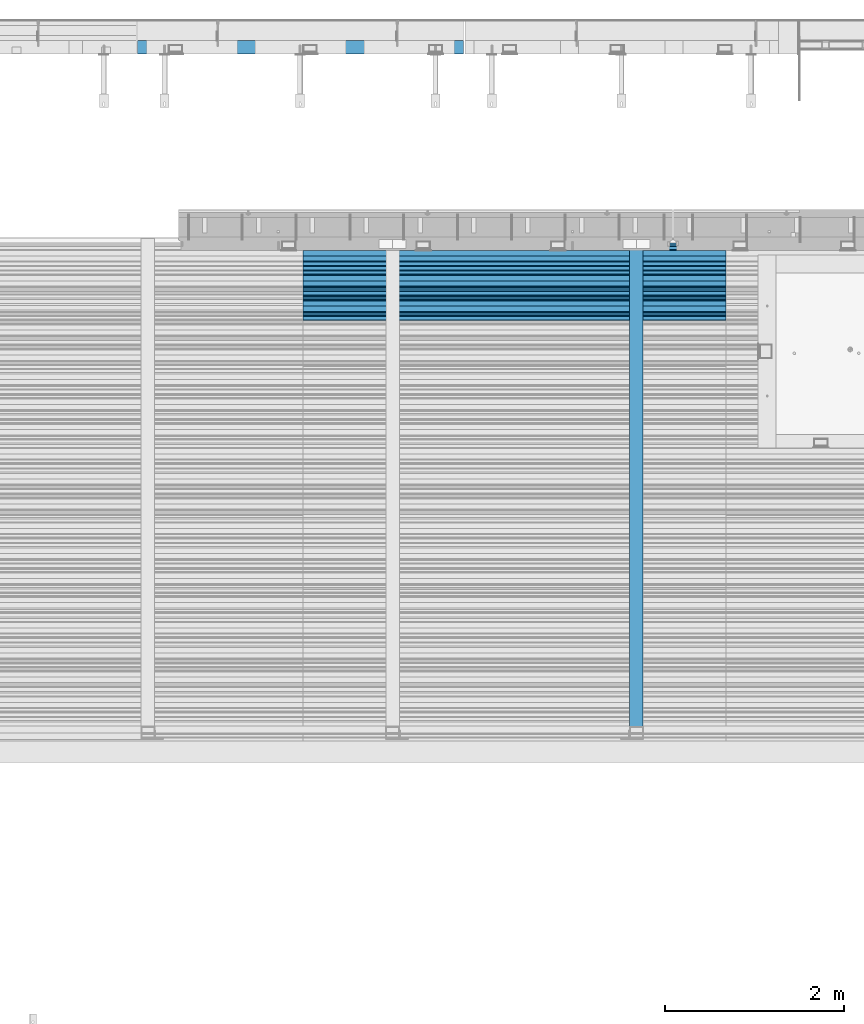
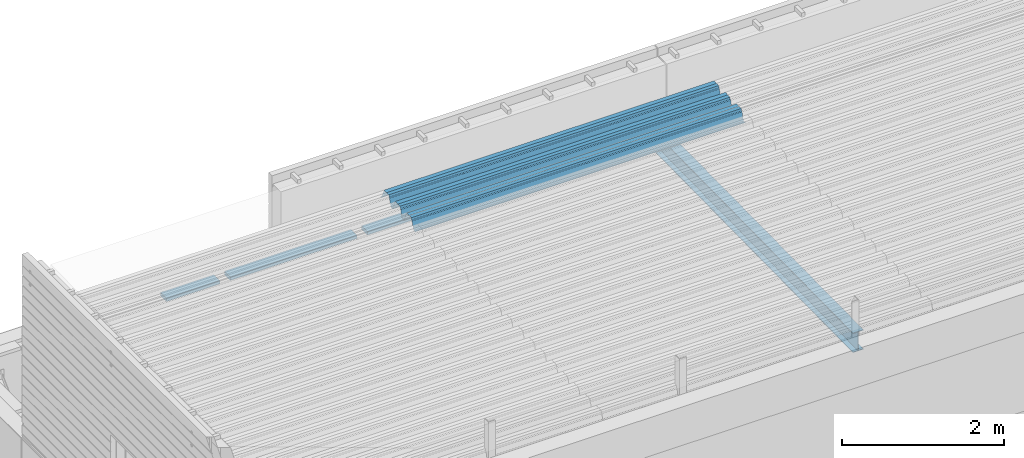
# One storey, part 36 of 153: 3 beams, 3 elements without a shape of their own.
"""IFC2X3 building model written with IfcOpenShell, lengths in millimetres."""

from ifc_helpers import new_model, si_unit, frame, origin_with_axes, place, context, subcontext, project, spatial, faceted_brep, material, type_object, element, aggregate, save


model = new_model("IFC2X3")

# Units and contexts
model_context = context("Model", 3, precision=1e-05, world=origin_with_axes())
body_context = subcontext(model_context, "Body", "Model", "MODEL_VIEW")
ifc_project = project(units=[si_unit("LENGTHUNIT", "METRE", prefix="MILLI"), si_unit("AREAUNIT", "SQUARE_METRE"), si_unit("VOLUMEUNIT", "CUBIC_METRE"), si_unit("MASSUNIT", "GRAM", prefix="KILO"), si_unit("TIMEUNIT", "SECOND"), si_unit("PLANEANGLEUNIT", "RADIAN"), si_unit("SOLIDANGLEUNIT", "STERADIAN"), si_unit("THERMODYNAMICTEMPERATUREUNIT", "DEGREE_CELSIUS"), si_unit("LUMINOUSINTENSITYUNIT", "LUMEN")], contexts=[model_context])

# Site, building, storey
site_placement = place(None, origin_with_axes())
site = spatial("IfcSite", under=ifc_project, at=site_placement, CompositionType="ELEMENT")
building_placement = place(site_placement, origin_with_axes())
building = spatial("IfcBuilding", under=site, at=building_placement, CompositionType="ELEMENT")
storey_placement = place(building_placement, origin_with_axes())
storey = spatial("IfcBuildingStorey", under=building, at=storey_placement, Name="8", CompositionType="ELEMENT", Elevation=0.0)

# Assembly, beam
assembly_1_placement = place(storey_placement, origin_with_axes())
assembly_1 = element("IfcElementAssembly", 1, at=assembly_1_placement, inside=storey, AssemblyPlace="NOTDEFINED", PredefinedType="REINFORCEMENT_UNIT")
ifc_material_1 = material(Name="TIMBER")
beam_type_1 = type_object("IfcBeamType", PredefinedType="NOTDEFINED")
beam_1_placement = place(assembly_1_placement, frame((10692.5, 22695.0, 103545.0), z_axis=(0.0, 0.0, 1.0), x_axis=(1.0, 0.0, 0.0)))
beam_1 = element("IfcBeam", 2, at=beam_1_placement, type_object=beam_type_1, material=ifc_material_1, context=body_context, shape_type="Brep", body=[
    faceted_brep([(0.0, -75.0, -25.0), (1.81898940354586e-12, -75.0000000000009, 25.0), (1.81898940354586e-12, 75.0, 25.0), (0.0, 75.0, -25.0), (761.499676343077, -75.0, -25.0), (761.499676343077, -75.0, 25.0), (761.499640793076, 74.9998429442203, 25.0), (761.499640793076, 75.0, -25.0), (2871.49964079283, 74.9998784942218, 25.0), (2871.49964079283, 75.0, -25.0), (2871.49967634307, -75.0, -25.0), (2871.49967634307, -75.0, 25.0), (3632.5, -75.0, 25.0), (3632.5, -75.0, -25.0), (3632.5, 75.0, -25.0), (3632.5, 75.0, 25.0), (2721.49964079308, 74.9998429442203, 25.0), (2721.49967634308, -75.0, 25.0), (2721.49967634308, -75.0, -25.0), (2721.49964079308, 75.0, -25.0), (911.499640792827, 74.9998784942218, 25.0), (911.499640792827, 75.0, -25.0), (911.499676343072, -75.0, -25.0), (911.499676343072, -75.0, 25.0)], [[[0, 1, 2, 3]], [[1, 0, 4, 5]], [[2, 1, 5, 6]], [[3, 2, 6, 7]], [[0, 3, 7, 4]], [[6, 5, 4, 7]], [[8, 9, 10, 11]], [[12, 13, 14, 15]], [[12, 15, 8, 11]], [[13, 12, 11, 10]], [[14, 13, 10, 9]], [[15, 14, 9, 8]], [[16, 17, 18, 19]], [[20, 21, 22, 23]], [[21, 20, 16, 19]], [[22, 21, 19, 18]], [[23, 22, 18, 17]], [[20, 23, 17, 16]]]),
])
aggregate(assembly_1, [beam_1])

assembly_2_placement = place(storey_placement, origin_with_axes())
assembly_2 = element("IfcElementAssembly", 3, at=assembly_2_placement, inside=storey, Name="Steel Assembly", AssemblyPlace="NOTDEFINED", PredefinedType="RIGID_FRAME")
ifc_material_2 = material(Name="STEEL/S355J2")
beam_type_2 = type_object("IfcBeamType", Name="IPE300", PredefinedType="NOTDEFINED")
beam_2_placement = place(assembly_2_placement, frame((16252.0, 15128.0908589909, 105518.668698015), z_axis=(0.0, -0.0124990270013869, 0.999921884110963), x_axis=(0.0, 0.999921884110963, 0.0124990270013883)))
beam_2 = element("IfcBeam", 4, at=beam_2_placement, type_object=beam_type_2, material=ifc_material_2, ObjectType="IPE300", context=body_context, shape_type="Brep", body=[
    faceted_brep([(3.63797880709171e-12, 75.0, -149.999999999985), (0.0, 75.0, -139.300000189993), (5440.87494889885, 75.0, -139.300000189993), (5440.87494889886, 75.0, -150.0), (0.0, 3.5499999525, -139.300000189993), (5440.87494889885, 3.5499999525, -139.300000189993), (0.0, 3.5499999525, 139.300000190022), (5440.87494889885, 3.5499999525, 139.300000190022), (0.0, 75.0, 139.300000190022), (5440.87494889885, 75.0, 139.300000190022), (3.63797880709171e-12, 75.0, 150.0), (5440.87494889885, 75.0, 150.0), (3.63797880709171e-12, -75.0, 150.0), (5440.87494889885, -75.0, 150.0), (0.0, -75.0, 139.300000190022), (5440.87494889885, -75.0, 139.300000190022), (0.0, -3.5499999525, 139.300000190022), (5440.87494889885, -3.5499999525, 139.300000190022), (0.0, -3.5499999525, -139.300000189993), (5440.87494889885, -3.5499999525, -139.300000189993), (0.0, -75.0, -139.300000189993), (5440.87494889885, -75.0, -139.300000189993), (3.63797880709171e-12, -75.0, -149.999999999985), (5440.87494889886, -75.0, -150.0)], [[[0, 1, 2, 3]], [[1, 4, 5, 2]], [[4, 6, 7, 5]], [[6, 8, 9, 7]], [[8, 10, 11, 9]], [[10, 12, 13, 11]], [[12, 14, 15, 13]], [[14, 16, 17, 15]], [[16, 18, 19, 17]], [[18, 20, 21, 19]], [[20, 22, 23, 21]], [[22, 0, 3, 23]], [[5, 7, 9, 11, 13, 15, 17, 19, 21, 23, 3, 2]], [[22, 20, 18, 16, 14, 12, 10, 8, 6, 4, 1, 0]]]),
])
aggregate(assembly_2, [beam_2])

assembly_3_placement = place(storey_placement, origin_with_axes())
assembly_3 = element("IfcElementAssembly", 5, at=assembly_3_placement, inside=storey, Name="Steel Assembly", AssemblyPlace="NOTDEFINED", PredefinedType="RIGID_FRAME")
beam_type_3 = type_object("IfcBeamType", Name="W", PredefinedType="NOTDEFINED")
beam_3_placement = place(assembly_3_placement, frame((17251.9999999917, 20081.9521353192, 105808.609793004), z_axis=(0.0, -0.0124990270013869, 0.999921884110963), x_axis=(-1.0, 3.00000001838171e-08, 0.0)))
beam_3 = element("IfcBeam", 6, at=beam_3_placement, type_object=beam_type_3, material=ifc_material_2, ObjectType="W", context=body_context, shape_type="Brep", body=[
    faceted_brep([(0.0, -412.839996337891, -77.0100021362159), (0.0, -409.160003662109, -77.0100021362014), (4717.0, -409.160003662109, -77.0100021362159), (4717.0, -412.839996337891, -77.0100021362159), (0.0, -408.070007324222, -73.4800033569045), (4717.0, -408.070007324222, -73.480003356919), (0.0, -400.339996337894, -48.0600013732619), (4717.0, -400.339996337894, -48.0600013732765), (0.0, -399.459991455082, -46.5600013732619), (4717.0, -399.459991455078, -46.5600013732765), (0.0, -390.329986572269, -36.5499992370314), (4717.0, -390.329986572266, -36.549999237046), (0.0, -389.19000244141, -34.6300010680861), (4717.0, -389.190002441403, -34.6300010681007), (0.0, -367.820007324222, 35.3400001526024), (4717.0, -367.820007324219, 35.3400001525879), (0.0, -366.989990234379, 36.8499984741502), (4717.0, -366.989990234375, 36.8499984741356), (0.0, -357.809997558597, 46.8600006103807), (4717.0, -357.809997558594, 46.8600006103661), (0.0, -356.720001220707, 48.7700004577782), (4717.0, -356.720001220703, 48.7700004577782), (0.0, -349.309997558594, 73.1500015258935), (4717.0, -349.309997558594, 73.1500015258935), (0.0, -347.850006103516, 75.2300033569481), (4717.0, -347.850006103516, 75.2300033569481), (0.0, -345.470001220707, 76.010002136245), (4717.0, -345.470001220703, 76.0100021362305), (0.0, -305.480010986332, 76.010002136245), (4717.0, -305.480010986324, 76.0100021362305), (0.0, -304.279998779301, 75.8000030517578), (4717.0, -304.279998779301, 75.8000030517724), (0.0, -291.679992675785, 71.6999969482567), (4717.0, -291.679992675785, 71.6999969482567), (0.0, -290.179992675789, 71.2300033569481), (4717.0, -290.179992675781, 71.2300033569481), (0.0, -288.720001220707, 71.6999969482567), (4717.0, -288.720001220703, 71.6999969482422), (0.0, -276.119995117191, 75.8000030517869), (4717.0, -276.119995117188, 75.8000030517724), (0.0, -274.929992675785, 76.010002136245), (4717.0, -274.929992675785, 76.010002136245), (0.0, -234.94000244141, 76.010002136245), (4717.0, -234.94000244141, 76.010002136245), (0.0, -232.550003051758, 75.2300033569627), (4717.0, -232.550003051758, 75.2300033569481), (0.0, -231.100006103519, 73.1500015258935), (4717.0, -231.100006103516, 73.1500015258789), (0.0, -223.679992675785, 48.7700004577782), (4717.0, -223.679992675781, 48.7700004577782), (0.0, -222.589996337894, 46.8600006103661), (4717.0, -222.589996337891, 46.8600006103516), (0.0, -213.410003662113, 36.8499984741502), (4717.0, -213.410003662109, 36.8499984741356), (0.0, -212.529998779301, 35.3400001526024), (4717.0, -212.529998779297, 35.3400001526024), (0.0, -191.160003662109, -34.6300010681007), (4717.0, -191.160003662109, -34.6300010681007), (0.0, -190.070007324222, -36.5499992370605), (4717.0, -190.070007324215, -36.549999237046), (0.0, -180.940002441406, -46.560001373291), (4717.0, -180.940002441406, -46.5600013732765), (0.0, -180.059997558597, -48.0600013732619), (4717.0, -180.059997558594, -48.0600013732765), (0.0, -172.330001831055, -73.480003356919), (4717.0, -172.330001831055, -73.480003356919), (0.0, -171.240005493168, -77.0100021362159), (4717.0, -171.240005493164, -77.0100021362159), (0.0, -129.330001831062, -77.0100021362014), (4717.0, -129.330001831055, -77.0100021362159), (0.0, -128.300003051761, -73.480003356919), (4717.0, -128.300003051758, -73.4800033569336), (0.0, -120.51999664307, -48.0600013732765), (4717.0, -120.519996643063, -48.0600013732765), (0.0, -119.629997253418, -46.5600013732765), (4717.0, -119.629997253418, -46.5600013732765), (0.0, -110.500000000004, -36.5499992370314), (4717.0, -110.5, -36.549999237046), (0.0, -109.419998168949, -34.6300010680861), (4717.0, -109.419998168945, -34.6300010681007), (0.0, -88.0500030517615, 35.3400001526024), (4717.0, -88.0500030517578, 35.3400001526024), (0.0, -87.160003662113, 36.8499984741356), (4717.0, -87.160003662113, 36.8499984741356), (0.0, -78.0400009155273, 46.8600006103807), (4717.0, -78.0400009155273, 46.8600006103661), (0.0, -76.8899993896557, 48.7700004577782), (4717.0, -76.8899993896521, 48.7700004577782), (0.0, -69.4800033569336, 73.1500015258935), (4717.0, -69.4800033569336, 73.1500015258935), (0.0, -68.0299987793042, 75.2300033569336), (4717.0, -68.0299987792969, 75.2300033569481), (0.0, -65.6399993896521, 76.010002136245), (4717.0, -65.6399993896484, 76.010002136245), (0.0, -25.6499996185375, 76.0100021362596), (4717.0, -25.6499996185303, 76.010002136245), (0.0, -24.5100002288891, 75.8000030517724), (4717.0, -24.5100002288818, 75.8000030517724), (0.0, -11.8500003814697, 71.6999969482567), (4717.0, -11.8500003814661, 71.6999969482567), (0.0, -10.3999996185339, 71.2300033569481), (4717.0, -10.3999996185303, 71.2300033569336), (0.0, -8.89999961853391, 71.6999969482567), (4717.0, -8.89999961853391, 71.6999969482567), (0.0, 3.71000003814333, 75.8000030517724), (4717.0, 3.71000003814697, 75.8000030517869), (0.0, 4.90000009536379, 76.0100021362596), (4717.0, 4.90000009536379, 76.010002136245), (0.0, 44.8899993896484, 76.010002136245), (4717.0, 44.8899993896484, 76.010002136245), (0.0, 47.2799987792932, 75.2300033569481), (4717.0, 47.2799987792969, 75.2300033569481), (0.0, 48.6800003051721, 73.1500015258935), (4717.0, 48.6800003051758, 73.1500015258789), (0.0, 56.1500015258753, 48.7700004577782), (4717.0, 56.1500015258789, 48.7700004577782), (0.0, 57.2400016784632, 46.8600006103807), (4717.0, 57.2400016784632, 46.8600006103661), (0.0, 66.3700027465784, 36.8499984741211), (4717.0, 66.3700027465857, 36.8499984741356), (0.0, 67.2499999999964, 35.3400001526024), (4717.0, 67.2500000000036, 35.3400001526024), (0.0, 88.6200027465748, -34.6300010681007), (4717.0, 88.620002746582, -34.6300010681152), (0.0, 89.709999084469, -36.549999237046), (4717.0, 89.7099990844727, -36.5499992370605), (0.0, 98.8899993896412, -46.5600013732765), (4717.0, 98.8899993896484, -46.5600013732765), (0.0, 99.7699966430628, -48.0600013732765), (4717.0, 99.7699966430664, -48.060001373291), (0.0, 107.499999999996, -73.4800033569336), (4717.0, 107.5, -73.480003356919), (0.0, 108.589996337887, -77.0100021362014), (4717.0, 108.589996337894, -77.0100021362159), (0.0, 112.269996643063, -77.0100021362159), (4717.0, 112.269996643066, -77.0100021362159), (0.0, 146.759994506836, -77.0100021362159), (4717.0, 146.759994506836, -77.0100021362159), (0.0, 150.440002441403, -77.0100021362159), (4717.0, 150.440002441403, -77.0100021362305), (0.0, 151.529998779297, -73.480003356919), (4717.0, 151.529998779297, -73.4800033569336), (0.0, 159.30999755859, -48.0600013732765), (4717.0, 159.309997558594, -48.0600013732765), (0.0, 160.190002441406, -46.5600013732619), (4717.0, 160.190002441406, -46.5600013732765), (0.0, 169.320007324215, -36.549999237046), (4717.0, 169.320007324222, -36.5499992370605), (0.0, 170.410003662106, -34.6300010680861), (4717.0, 170.410003662109, -34.6300010681007), (0.0, 191.779998779293, 35.3400001526024), (4717.0, 191.779998779293, 35.3400001526024), (0.0, 192.660003662109, 36.8499984741502), (4717.0, 192.660003662109, 36.8499984741356), (0.0, 201.789993286129, 46.8600006103661), (4717.0, 201.789993286133, 46.8600006103661), (0.0, 202.880004882809, 48.7700004577637), (4717.0, 202.880004882813, 48.7700004577782), (0.0, 210.350006103512, 73.150001525908), (4717.0, 210.350006103516, 73.1500015258935), (0.0, 211.800003051754, 75.2300033569481), (4717.0, 211.800003051758, 75.2300033569336), (0.0, 214.190002441406, 76.010002136245), (4717.0, 214.19000244141, 76.010002136245), (0.0, 254.179992675778, 76.010002136245), (4717.0, 254.179992675778, 76.010002136245), (0.0, 255.320007324215, 75.8000030517869), (4717.0, 255.320007324222, 75.8000030517724), (0.0, 267.980010986324, 71.6999969482713), (4717.0, 267.980010986328, 71.6999969482567), (0.0, 269.429992675778, 71.2300033569481), (4717.0, 269.429992675781, 71.2300033569481), (0.0, 270.880004882809, 71.6999969482567), (4717.0, 270.880004882813, 71.6999969482567), (0.0, 283.540008544918, 75.8000030517869), (4717.0, 283.540008544918, 75.8000030517724), (0.0, 284.679992675778, 76.010002136245), (4717.0, 284.679992675778, 76.010002136245), (0.0, 324.670013427731, 76.010002136245), (4717.0, 324.670013427738, 76.010002136245), (0.0, 327.049987792969, 75.2300033569627), (4717.0, 327.049987792969, 75.2300033569481), (0.0, 328.510009765625, 73.1500015258789), (4717.0, 328.510009765625, 73.1500015258935), (0.0, 335.980010986324, 48.7700004577782), (4717.0, 335.980010986328, 48.7700004577782), (0.0, 337.05999755859, 46.8600006103661), (4717.0, 337.059997558594, 46.8600006103516), (0.0, 346.190002441399, 36.8499984741356), (4717.0, 346.190002441406, 36.8499984741211), (0.0, 347.079986572266, 35.3400001526024), (4717.0, 347.079986572266, 35.3400001526024), (0.0, 368.450012207028, -34.6300010680861), (4717.0, 368.450012207035, -34.6300010681007), (0.0, 369.529998779293, -36.5499992370314), (4717.0, 369.529998779297, -36.549999237046), (0.0, 378.660003662106, -46.5600013732619), (4717.0, 378.660003662106, -46.5600013732765), (0.0, 379.540008544918, -48.0600013732619), (4717.0, 379.540008544922, -48.0600013732765), (0.0, 387.329986572262, -73.480003356919), (4717.0, 387.329986572266, -73.4800033569045), (0.0, 388.410003662109, -77.0100021362159), (4717.0, 388.410003662109, -77.0100021362159), (0.0, 392.100006103512, -77.0100021362159), (4717.0, 392.100006103519, -77.0100021362159), (0.0, 426.589996337887, -77.0100021362159), (4717.0, 426.589996337891, -77.0100021362159), (0.0, 430.269989013668, -77.0100021362159), (4717.0, 430.269989013672, -77.0100021362305), (0.0, 431.359985351559, -73.4800033569045), (4717.0, 431.359985351563, -73.480003356919), (0.0, 433.179992675778, -67.5699996948097), (4717.0, 433.179992675781, -67.5699996948097), (0.0, 432.220001220699, -67.2699966430373), (4717.0, 432.220001220703, -67.2699966430519), (0.0, 430.410003662106, -73.1800003051612), (4717.0, 430.410003662106, -73.1800003051758), (0.0, 429.529998779293, -76.0100021362159), (4717.0, 429.529998779293, -76.0100021362159), (0.0, 426.589996337891, -76.0100021362159), (4717.0, 426.589996337891, -76.0100021362159), (0.0, 392.100006103512, -76.0100021362159), (4717.0, 392.100006103516, -76.0100021362159), (0.0, 389.149993896481, -76.0100021362014), (4717.0, 389.149993896484, -76.0100021362159), (0.0, 388.279998779293, -73.1800003051467), (4717.0, 388.279998779301, -73.1800003051612), (0.0, 380.470001220699, -47.659999847383), (4717.0, 380.470001220703, -47.6599998473976), (0.0, 379.470001220699, -45.9599990844436), (4717.0, 379.470001220703, -45.9599990844581), (0.0, 370.350006103512, -35.9599990844581), (4717.0, 370.350006103519, -35.9599990844581), (0.0, 369.369995117184, -34.2299995422218), (4717.0, 369.369995117184, -34.2299995422218), (0.0, 347.999999999996, 35.7500000000146), (4717.0, 348.0, 35.7500000000146), (0.0, 346.999999999996, 37.4399986267235), (4717.0, 347.000000000004, 37.4399986267235), (0.0, 337.880004882809, 47.450000762954), (4717.0, 337.880004882809, 47.4500007629395), (0.0, 336.899993896481, 49.1699981689453), (4717.0, 336.899993896484, 49.1699981689599), (0.0, 329.420013427731, 73.5999984741356), (4717.0, 329.420013427734, 73.5999984741356), (0.0, 327.679992675781, 76.0699996948533), (4717.0, 327.679992675781, 76.0699996948388), (0.0, 324.829986572262, 77.010002136245), (4717.0, 324.829986572266, 77.0100021362305), (0.0, 284.589996337887, 77.010002136245), (4717.0, 284.589996337891, 77.010002136245), (0.0, 283.290008544922, 76.769996643081), (4717.0, 283.290008544922, 76.769996643081), (0.0, 270.570007324215, 72.6500015258935), (4717.0, 270.570007324219, 72.6500015258935), (0.0, 269.429992675781, 72.2799987793114), (4717.0, 269.429992675781, 72.2799987793114), (0.0, 268.279998779293, 72.650001525908), (4717.0, 268.279998779297, 72.6500015258935), (0.0, 255.570007324219, 76.769996643081), (4717.0, 255.570007324219, 76.769996643081), (0.0, 254.270004272461, 77.0100021362596), (4717.0, 254.270004272461, 77.010002136245), (0.0, 214.029998779293, 77.0100021362596), (4717.0, 214.029998779297, 77.010002136245), (0.0, 211.179992675781, 76.0699996948388), (4717.0, 211.179992675781, 76.0699996948533), (0.0, 209.440002441403, 73.5999984741356), (4717.0, 209.44000244141, 73.5999984741211), (0.0, 201.960006713864, 49.1699981689599), (4717.0, 201.960006713867, 49.1699981689453), (0.0, 200.979995727532, 47.450000762954), (4717.0, 200.979995727539, 47.4500007629395), (0.0, 191.850006103508, 37.4399986267235), (4717.0, 191.850006103516, 37.439998626709), (0.0, 190.860000610352, 35.7500000000146), (4717.0, 190.860000610352, 35.75), (0.0, 169.49000549316, -34.2299995422218), (4717.0, 169.49000549316, -34.2299995422363), (0.0, 168.509994506832, -35.9599990844581), (4717.0, 168.509994506836, -35.9599990844581), (0.0, 159.380004882805, -45.9599990844436), (4717.0, 159.380004882813, -45.9599990844581), (0.0, 158.389999389645, -47.6599998473976), (4717.0, 158.389999389645, -47.6599998474121), (0.0, 150.580001831051, -73.1800003051612), (4717.0, 150.580001831058, -73.1800003051758), (0.0, 149.710006713864, -76.0100021362159), (4717.0, 149.710006713867, -76.0100021362159), (0.0, 146.759994506836, -76.0100021362159), (4717.0, 146.759994506836, -76.0100021362159), (0.0, 112.269996643063, -76.0100021362159), (4717.0, 112.269996643063, -76.0100021362159), (0.0, 109.319999694821, -76.0100021362159), (4717.0, 109.319999694821, -76.0100021362159), (0.0, 108.449996948239, -73.1900024413917), (4717.0, 108.449996948242, -73.1900024414063), (0.0, 100.690002441406, -47.659999847383), (4717.0, 100.69000244141, -47.6599998473976), (0.0, 99.6999969482386, -45.9599990844581), (4717.0, 99.6999969482422, -45.9599990844581), (0.0, 90.5199966430664, -35.9599990844581), (4717.0, 90.5199966430664, -35.9599990844727), (0.0, 89.5400009155273, -34.2299995422218), (4717.0, 89.5400009155273, -34.2299995422218), (0.0, 68.1699981689417, 35.7500000000146), (4717.0, 68.1699981689453, 35.7500000000146), (0.0, 67.1699981689417, 37.4399986267235), (4717.0, 67.1699981689453, 37.4399986267235), (0.0, 58.0499992370569, 47.4500007629686), (4717.0, 58.0499992370605, 47.450000762954), (0.0, 57.0699996948206, 49.1699981689599), (4717.0, 57.0699996948279, 49.1699981689453), (0.0, 49.5900001525843, 73.5899963379052), (4717.0, 49.5900001525879, 73.5899963378906), (0.0, 47.9099998474085, 76.0699996948388), (4717.0, 47.9099998474121, 76.0699996948242), (0.0, 45.0499992370569, 77.010002136245), (4717.0, 45.0499992370605, 77.010002136245), (0.0, 4.82000017165774, 77.010002136245), (4717.0, 4.82000017166138, 77.010002136245), (0.0, 3.47000002860659, 76.7699966430955), (4717.0, 3.47000002860659, 76.769996643081), (0.0, -9.19999980926514, 72.6500015258935), (4717.0, -9.19999980926514, 72.6500015258789), (0.0, -10.3900003433264, 72.2799987792969), (4717.0, -10.3900003433228, 72.2799987793114), (0.0, -11.5399999618567, 72.6500015258935), (4717.0, -11.5399999618494, 72.6500015258935), (0.0, -24.2600002288855, 76.769996643081), (4717.0, -24.2600002288818, 76.769996643081), (0.0, -25.559999465946, 77.0100021362596), (4717.0, -25.5599994659424, 77.010002136245), (0.0, -65.8000030517615, 77.0100021362596), (4717.0, -65.8000030517578, 77.010002136245), (0.0, -68.6500015258862, 76.0699996948533), (4717.0, -68.6500015258825, 76.0699996948388), (0.0, -70.3899993896521, 73.5999984741356), (4717.0, -70.3899993896484, 73.5999984741211), (0.0, -77.8199996948242, 49.1800003051903), (4717.0, -77.8199996948242, 49.1800003051903), (0.0, -78.8399963378943, 47.450000762954), (4717.0, -78.8399963378906, 47.4500007629395), (0.0, -87.9700012207031, 37.4399986267235), (4717.0, -87.9700012207031, 37.4399986267235), (0.0, -88.9700012207068, 35.7500000000146), (4717.0, -88.9700012207031, 35.75), (0.0, -110.339996337894, -34.2299995422218), (4717.0, -110.339996337887, -34.2299995422218), (0.0, -111.319999694828, -35.9599990844581), (4717.0, -111.319999694824, -35.9599990844581), (0.0, -120.440002441406, -45.9599990844436), (4717.0, -120.440002441406, -45.9599990844581), (0.0, -121.44000244141, -47.6599998473976), (4717.0, -121.440002441403, -47.6599998473976), (0.0, -129.250000000004, -73.1900024413771), (4717.0, -129.25, -73.1900024413917), (0.0, -130.080001831062, -76.0100021362159), (4717.0, -130.080001831055, -76.0100021362159), (0.0, -170.5, -76.0100021362014), (4717.0, -170.5, -76.0100021362159), (0.0, -171.380004882816, -73.1900024413917), (4717.0, -171.380004882813, -73.1900024414063), (0.0, -179.139999389652, -47.6599998473976), (4717.0, -179.139999389648, -47.6599998473976), (0.0, -180.130004882816, -45.9599990844581), (4717.0, -180.130004882813, -45.9599990844581), (0.0, -189.259994506836, -35.9599990844581), (4717.0, -189.259994506832, -35.9599990844581), (0.0, -190.240005493168, -34.2299995422218), (4717.0, -190.240005493164, -34.2299995422218), (0.0, -211.610000610355, 35.7500000000146), (4717.0, -211.610000610352, 35.7500000000146), (0.0, -212.600006103519, 37.4399986267381), (4717.0, -212.600006103519, 37.4399986267235), (0.0, -221.779998779301, 47.450000762954), (4717.0, -221.779998779293, 47.4500007629395), (0.0, -222.75999450684, 49.1699981689599), (4717.0, -222.759994506836, 49.1699981689599), (0.0, -230.190002441406, 73.5999984741356), (4717.0, -230.190002441406, 73.5999984741211), (0.0, -231.919998168945, 76.0699996948388), (4717.0, -231.919998168945, 76.0699996948388), (0.0, -234.779998779301, 77.010002136245), (4717.0, -234.779998779293, 77.010002136245), (0.0, -275.010009765629, 77.010002136245), (4717.0, -275.010009765625, 77.0100021362305), (0.0, -276.359985351563, 76.769996643081), (4717.0, -276.359985351563, 76.7699966430664), (0.0, -289.029998779297, 72.6500015258789), (4717.0, -289.029998779297, 72.6500015258935), (0.0, -290.179992675785, 72.2799987793114), (4717.0, -290.179992675785, 72.2799987793114), (0.0, -291.380004882816, 72.650001525908), (4717.0, -291.380004882813, 72.6500015258935), (0.0, -304.040008544926, 76.769996643081), (4717.0, -304.040008544918, 76.769996643081), (0.0, -305.390014648441, 77.010002136245), (4717.0, -305.390014648438, 77.010002136245), (0.0, -345.63000488282, 77.0100021362596), (4717.0, -345.630004882813, 77.010002136245), (0.0, -348.480010986332, 76.0699996948388), (4717.0, -348.480010986324, 76.0699996948388), (0.0, -350.220001220707, 73.5999984741356), (4717.0, -350.220001220703, 73.5999984741211), (0.0, -357.649993896492, 49.1699981689599), (4717.0, -357.649993896484, 49.1699981689744), (0.0, -358.63000488282, 47.450000762954), (4717.0, -358.630004882813, 47.450000762954), (0.0, -367.809997558594, 37.4300003051903), (4717.0, -367.809997558594, 37.4300003051903), (0.0, -368.750000000004, 35.7299995422654), (4717.0, -368.75, 35.7299995422509), (0.0, -390.109985351566, -34.2200012207031), (4717.0, -390.109985351563, -34.2200012206886), (0.0, -391.140014648441, -35.9500007629249), (4717.0, -391.140014648438, -35.9500007629103), (0.0, -400.269989013676, -45.9599990844436), (4717.0, -400.269989013672, -45.9599990844581), (0.0, -401.269989013672, -47.6599998473976), (4717.0, -401.269989013672, -47.6599998473976), (0.0, -409.029998779297, -73.1900024413917), (4717.0, -409.029998779297, -73.1900024413917), (0.0, -409.899993896488, -76.0100021362159), (4717.0, -409.899993896481, -76.0100021362305), (0.0, -412.839996337891, -76.0100021362159), (4717.0, -412.839996337891, -76.0100021362305), (0.0, -433.179992675785, -76.0100021362159), (4717.0, -433.179992675781, -76.0100021362159), (0.0, -433.179992675785, -77.0100021362159), (4717.0, -433.179992675785, -77.0100021362305)], [[[0, 1, 2, 3]], [[1, 4, 5, 2]], [[4, 6, 7, 5]], [[6, 8, 9, 7]], [[8, 10, 11, 9]], [[10, 12, 13, 11]], [[12, 14, 15, 13]], [[14, 16, 17, 15]], [[16, 18, 19, 17]], [[18, 20, 21, 19]], [[20, 22, 23, 21]], [[22, 24, 25, 23]], [[24, 26, 27, 25]], [[26, 28, 29, 27]], [[28, 30, 31, 29]], [[30, 32, 33, 31]], [[32, 34, 35, 33]], [[34, 36, 37, 35]], [[36, 38, 39, 37]], [[38, 40, 41, 39]], [[40, 42, 43, 41]], [[42, 44, 45, 43]], [[44, 46, 47, 45]], [[46, 48, 49, 47]], [[48, 50, 51, 49]], [[50, 52, 53, 51]], [[52, 54, 55, 53]], [[54, 56, 57, 55]], [[56, 58, 59, 57]], [[58, 60, 61, 59]], [[60, 62, 63, 61]], [[62, 64, 65, 63]], [[64, 66, 67, 65]], [[66, 68, 69, 67]], [[68, 70, 71, 69]], [[70, 72, 73, 71]], [[72, 74, 75, 73]], [[74, 76, 77, 75]], [[76, 78, 79, 77]], [[78, 80, 81, 79]], [[80, 82, 83, 81]], [[82, 84, 85, 83]], [[84, 86, 87, 85]], [[86, 88, 89, 87]], [[88, 90, 91, 89]], [[90, 92, 93, 91]], [[92, 94, 95, 93]], [[94, 96, 97, 95]], [[96, 98, 99, 97]], [[98, 100, 101, 99]], [[100, 102, 103, 101]], [[102, 104, 105, 103]], [[104, 106, 107, 105]], [[106, 108, 109, 107]], [[108, 110, 111, 109]], [[110, 112, 113, 111]], [[112, 114, 115, 113]], [[114, 116, 117, 115]], [[116, 118, 119, 117]], [[118, 120, 121, 119]], [[120, 122, 123, 121]], [[122, 124, 125, 123]], [[124, 126, 127, 125]], [[126, 128, 129, 127]], [[128, 130, 131, 129]], [[130, 132, 133, 131]], [[132, 134, 135, 133]], [[134, 136, 137, 135]], [[136, 138, 139, 137]], [[138, 140, 141, 139]], [[140, 142, 143, 141]], [[142, 144, 145, 143]], [[144, 146, 147, 145]], [[146, 148, 149, 147]], [[148, 150, 151, 149]], [[150, 152, 153, 151]], [[152, 154, 155, 153]], [[154, 156, 157, 155]], [[156, 158, 159, 157]], [[158, 160, 161, 159]], [[160, 162, 163, 161]], [[162, 164, 165, 163]], [[164, 166, 167, 165]], [[166, 168, 169, 167]], [[168, 170, 171, 169]], [[170, 172, 173, 171]], [[172, 174, 175, 173]], [[174, 176, 177, 175]], [[176, 178, 179, 177]], [[178, 180, 181, 179]], [[180, 182, 183, 181]], [[182, 184, 185, 183]], [[184, 186, 187, 185]], [[186, 188, 189, 187]], [[188, 190, 191, 189]], [[190, 192, 193, 191]], [[192, 194, 195, 193]], [[194, 196, 197, 195]], [[196, 198, 199, 197]], [[198, 200, 201, 199]], [[200, 202, 203, 201]], [[202, 204, 205, 203]], [[204, 206, 207, 205]], [[206, 208, 209, 207]], [[208, 210, 211, 209]], [[210, 212, 213, 211]], [[212, 214, 215, 213]], [[214, 216, 217, 215]], [[216, 218, 219, 217]], [[218, 220, 221, 219]], [[220, 222, 223, 221]], [[222, 224, 225, 223]], [[224, 226, 227, 225]], [[226, 228, 229, 227]], [[228, 230, 231, 229]], [[230, 232, 233, 231]], [[232, 234, 235, 233]], [[234, 236, 237, 235]], [[236, 238, 239, 237]], [[238, 240, 241, 239]], [[240, 242, 243, 241]], [[242, 244, 245, 243]], [[244, 246, 247, 245]], [[246, 248, 249, 247]], [[248, 250, 251, 249]], [[250, 252, 253, 251]], [[252, 254, 255, 253]], [[254, 256, 257, 255]], [[256, 258, 259, 257]], [[258, 260, 261, 259]], [[260, 262, 263, 261]], [[262, 264, 265, 263]], [[264, 266, 267, 265]], [[266, 268, 269, 267]], [[268, 270, 271, 269]], [[270, 272, 273, 271]], [[272, 274, 275, 273]], [[274, 276, 277, 275]], [[276, 278, 279, 277]], [[278, 280, 281, 279]], [[280, 282, 283, 281]], [[282, 284, 285, 283]], [[284, 286, 287, 285]], [[286, 288, 289, 287]], [[288, 290, 291, 289]], [[290, 292, 293, 291]], [[292, 294, 295, 293]], [[294, 296, 297, 295]], [[296, 298, 299, 297]], [[298, 300, 301, 299]], [[300, 302, 303, 301]], [[302, 304, 305, 303]], [[304, 306, 307, 305]], [[306, 308, 309, 307]], [[308, 310, 311, 309]], [[310, 312, 313, 311]], [[312, 314, 315, 313]], [[314, 316, 317, 315]], [[316, 318, 319, 317]], [[318, 320, 321, 319]], [[320, 322, 323, 321]], [[322, 324, 325, 323]], [[324, 326, 327, 325]], [[326, 328, 329, 327]], [[328, 330, 331, 329]], [[330, 332, 333, 331]], [[332, 334, 335, 333]], [[334, 336, 337, 335]], [[336, 338, 339, 337]], [[338, 340, 341, 339]], [[340, 342, 343, 341]], [[342, 344, 345, 343]], [[344, 346, 347, 345]], [[346, 348, 349, 347]], [[348, 350, 351, 349]], [[350, 352, 353, 351]], [[352, 354, 355, 353]], [[354, 356, 357, 355]], [[356, 358, 359, 357]], [[358, 360, 361, 359]], [[360, 362, 363, 361]], [[362, 364, 365, 363]], [[364, 366, 367, 365]], [[366, 368, 369, 367]], [[368, 370, 371, 369]], [[370, 372, 373, 371]], [[372, 374, 375, 373]], [[374, 376, 377, 375]], [[376, 378, 379, 377]], [[378, 380, 381, 379]], [[380, 382, 383, 381]], [[382, 384, 385, 383]], [[384, 386, 387, 385]], [[386, 388, 389, 387]], [[388, 390, 391, 389]], [[390, 392, 393, 391]], [[392, 394, 395, 393]], [[394, 396, 397, 395]], [[396, 398, 399, 397]], [[398, 400, 401, 399]], [[400, 402, 403, 401]], [[402, 404, 405, 403]], [[404, 406, 407, 405]], [[406, 408, 409, 407]], [[408, 410, 411, 409]], [[410, 412, 413, 411]], [[412, 414, 415, 413]], [[414, 416, 417, 415]], [[416, 418, 419, 417]], [[418, 420, 421, 419]], [[420, 422, 423, 421]], [[422, 424, 425, 423]], [[424, 426, 427, 425]], [[426, 428, 429, 427]], [[428, 430, 431, 429]], [[430, 0, 3, 431]], [[5, 7, 9, 11, 13, 15, 17, 19, 21, 23, 25, 27, 29, 31, 33, 35, 37, 39, 41, 43, 45, 47, 49, 51, 53, 55, 57, 59, 61, 63, 65, 67, 69, 71, 73, 75, 77, 79, 81, 83, 85, 87, 89, 91, 93, 95, 97, 99, 101, 103, 105, 107, 109, 111, 113, 115, 117, 119, 121, 123, 125, 127, 129, 131, 133, 135, 137, 139, 141, 143, 145, 147, 149, 151, 153, 155, 157, 159, 161, 163, 165, 167, 169, 171, 173, 175, 177, 179, 181, 183, 185, 187, 189, 191, 193, 195, 197, 199, 201, 203, 205, 207, 209, 211, 213, 215, 217, 219, 221, 223, 225, 227, 229, 231, 233, 235, 237, 239, 241, 243, 245, 247, 249, 251, 253, 255, 257, 259, 261, 263, 265, 267, 269, 271, 273, 275, 277, 279, 281, 283, 285, 287, 289, 291, 293, 295, 297, 299, 301, 303, 305, 307, 309, 311, 313, 315, 317, 319, 321, 323, 325, 327, 329, 331, 333, 335, 337, 339, 341, 343, 345, 347, 349, 351, 353, 355, 357, 359, 361, 363, 365, 367, 369, 371, 373, 375, 377, 379, 381, 383, 385, 387, 389, 391, 393, 395, 397, 399, 401, 403, 405, 407, 409, 411, 413, 415, 417, 419, 421, 423, 425, 427, 429, 431, 3, 2]], [[430, 428, 426, 424, 422, 420, 418, 416, 414, 412, 410, 408, 406, 404, 402, 400, 398, 396, 394, 392, 390, 388, 386, 384, 382, 380, 378, 376, 374, 372, 370, 368, 366, 364, 362, 360, 358, 356, 354, 352, 350, 348, 346, 344, 342, 340, 338, 336, 334, 332, 330, 328, 326, 324, 322, 320, 318, 316, 314, 312, 310, 308, 306, 304, 302, 300, 298, 296, 294, 292, 290, 288, 286, 284, 282, 280, 278, 276, 274, 272, 270, 268, 266, 264, 262, 260, 258, 256, 254, 252, 250, 248, 246, 244, 242, 240, 238, 236, 234, 232, 230, 228, 226, 224, 222, 220, 218, 216, 214, 212, 210, 208, 206, 204, 202, 200, 198, 196, 194, 192, 190, 188, 186, 184, 182, 180, 178, 176, 174, 172, 170, 168, 166, 164, 162, 160, 158, 156, 154, 152, 150, 148, 146, 144, 142, 140, 138, 136, 134, 132, 130, 128, 126, 124, 122, 120, 118, 116, 114, 112, 110, 108, 106, 104, 102, 100, 98, 96, 94, 92, 90, 88, 86, 84, 82, 80, 78, 76, 74, 72, 70, 68, 66, 64, 62, 60, 58, 56, 54, 52, 50, 48, 46, 44, 42, 40, 38, 36, 34, 32, 30, 28, 26, 24, 22, 20, 18, 16, 14, 12, 10, 8, 6, 4, 1, 0]]]),
])
aggregate(assembly_3, [beam_3])

save(model, "model.ifc")
